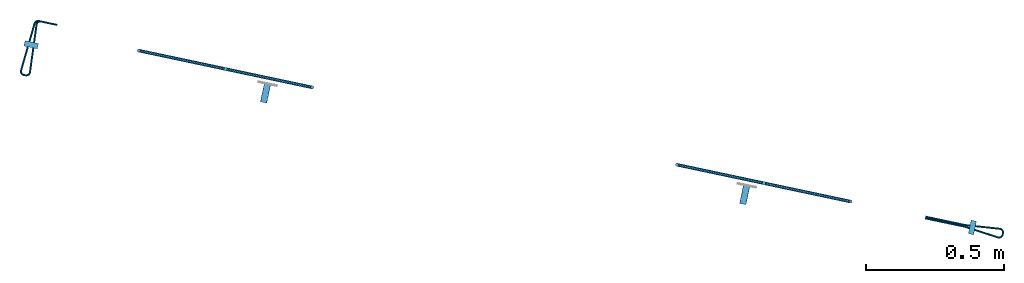
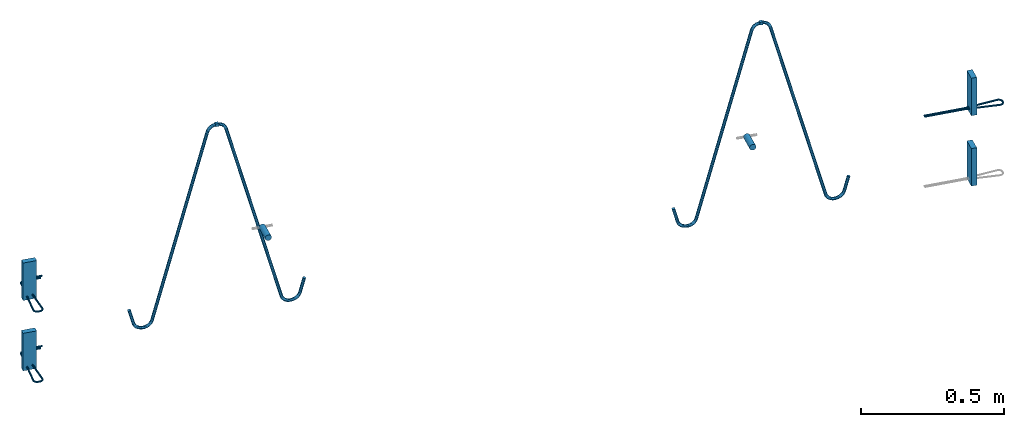
# One storey, part 1 of 2: 5 reinforcing bars, 4 beams, 4 plates, 8 elements without a shape of their own.
"""IFC2X3 building model written with IfcOpenShell, lengths in millimetres."""

from ifc_helpers import new_model, entity, si_unit, frame, origin_with_axes, origin_2d_with_axis, place, context, subcontext, project, spatial, polyline, rectangle, circle, outline, extrude, source, transform, mapped, material, type_object, element, aggregate, save


model = new_model("IFC2X3")

# Units and contexts
model_context = context("Model", 3, precision=1e-05, world=origin_with_axes())
body_context = subcontext(model_context, "Body", "Model", "MODEL_VIEW")
ifc_project = project(units=[si_unit("LENGTHUNIT", "METRE", prefix="MILLI"), si_unit("AREAUNIT", "SQUARE_METRE"), si_unit("VOLUMEUNIT", "CUBIC_METRE"), si_unit("MASSUNIT", "GRAM", prefix="KILO"), si_unit("TIMEUNIT", "SECOND"), si_unit("PLANEANGLEUNIT", "RADIAN"), si_unit("SOLIDANGLEUNIT", "STERADIAN"), si_unit("THERMODYNAMICTEMPERATUREUNIT", "DEGREE_CELSIUS"), si_unit("LUMINOUSINTENSITYUNIT", "LUMEN")], contexts=[model_context])

# Site, building, storey
site_placement = place(None, origin_with_axes())
site = spatial("IfcSite", under=ifc_project, at=site_placement, CompositionType="ELEMENT")
building_placement = place(site_placement, origin_with_axes())
building = spatial("IfcBuilding", under=site, at=building_placement, Name="Undefined", CompositionType="ELEMENT")
storey_placement = place(building_placement, origin_with_axes())
storey = spatial("IfcBuildingStorey", under=building, at=storey_placement, Name="Undefined", CompositionType="ELEMENT", Elevation=0.0)

# Assembly, beam
assembly_1_placement = place(storey_placement, origin_with_axes())
assembly_1 = element("IfcElementAssembly", 1, at=assembly_1_placement, inside=storey, Name="Steel Assembly", AssemblyPlace="NOTDEFINED", PredefinedType="RIGID_FRAME")
ifc_material_1 = material()
beam_type_1 = type_object("IfcBeamType", Name="D24", PredefinedType="NOTDEFINED")
beam_1_placement = place(assembly_1_placement, frame((1205.09818698197, 5717.25932723562, 670.000000007887), z_axis=(0.0, 0.0, 1.0), x_axis=(0.207475094085646, 0.978240300403818, 0.0)))
beam_1 = element("IfcBeam", 2, at=beam_1_placement, type_object=beam_type_1, material=ifc_material_1, ObjectType="D24", context=body_context, shape_type="SweptSolid", body=[
    extrude(circle(Radius=12.0, at=origin_2d_with_axis()), frame((70.0000000001488, 0.0, -1.13686837721616e-13), z_axis=(-1.0, 0.0, -6.18717668181185e-14), x_axis=(0.0, -1.0, 0.0)), (0.0, 0.0, 1.0), 70.0),
])
aggregate(assembly_1, [beam_1])

assembly_2_placement = place(storey_placement, origin_with_axes())
assembly_2 = element("IfcElementAssembly", 3, at=assembly_2_placement, inside=storey, Name="Steel Assembly", AssemblyPlace="NOTDEFINED", PredefinedType="RIGID_FRAME")
beam_2_placement = place(assembly_2_placement, frame((2946.52448996823, 5347.92002929886, 670.0), z_axis=(0.0, 0.0, 1.0), x_axis=(0.207475094085646, 0.978240300403818, 0.0)))
beam_2 = element("IfcBeam", 4, at=beam_2_placement, type_object=beam_type_1, material=ifc_material_1, ObjectType="D24", context=body_context, shape_type="SweptSolid", body=[
    extrude(circle(Radius=12.0, at=origin_2d_with_axis()), frame((70.0000000001488, 0.0, -1.13686837721616e-13), z_axis=(-1.0, 0.0, -6.18717668181185e-14), x_axis=(0.0, -1.0, 0.0)), (0.0, 0.0, 1.0), 70.0),
])
aggregate(assembly_2, [beam_2])

assembly_3_placement = place(storey_placement, origin_with_axes())
assembly_3 = element("IfcElementAssembly", 5, at=assembly_3_placement, inside=storey, Name="Steel Assembly", AssemblyPlace="NOTDEFINED", PredefinedType="RIGID_FRAME")
ifc_material_2 = material(Name="STEEL/S235JR")
beam_type_2 = type_object("IfcBeamType", Name="12X12", PredefinedType="NOTDEFINED")
beam_3_placement = place(assembly_3_placement, frame((3029.02681596481, 5422.63708332136, 1129.0), z_axis=(0.0, 0.0, 1.0), x_axis=(-0.978240300403818, 0.207475094085646, 0.0)))
beam_3 = element("IfcBeam", 6, at=beam_3_placement, type_object=beam_type_2, material=ifc_material_2, Name="SA_12", ObjectType="12X12", context=body_context, shape_type="SweptSolid", body=[
    extrude(rectangle(XDim=12.0, YDim=12.0, at=origin_2d_with_axis()), frame((11.9999999999924, 9.09494701772928e-13, 0.0), z_axis=(-1.0, 0.0, -6.18717668181185e-14), x_axis=(0.0, -1.0, 0.0)), (0.0, 0.0, 1.0), 12.0),
])

assembly_4_placement = place(storey_placement, origin_with_axes())
assembly_4 = element("IfcElementAssembly", 7, at=assembly_4_placement, inside=storey, Name="Steel Assembly", AssemblyPlace="NOTDEFINED", PredefinedType="RIGID_FRAME")
beam_4_placement = place(assembly_4_placement, frame((1060.80733155343, 5840.07697262104, 1129.0), z_axis=(0.0, 0.0, 1.0), x_axis=(0.978240300403819, -0.207475094085641, 0.0)))
beam_4 = element("IfcBeam", 8, at=beam_4_placement, type_object=beam_type_2, material=ifc_material_2, Name="SA_12", ObjectType="12X12", context=body_context, shape_type="SweptSolid", body=[
    extrude(rectangle(XDim=12.0, YDim=12.0, at=origin_2d_with_axis()), frame((11.9999999999924, 9.09494701772928e-13, 0.0), z_axis=(-1.0, 0.0, -6.18717668181185e-14), x_axis=(0.0, -1.0, 0.0)), (0.0, 0.0, 1.0), 12.0),
])

# Assembly, plate
assembly_5_placement = place(storey_placement, origin_with_axes())
assembly_5 = element("IfcElementAssembly", 9, at=assembly_5_placement, inside=storey, Name="Steel Assembly", AssemblyPlace="NOTDEFINED", PredefinedType="RIGID_FRAME")
ifc_material_3 = material(Name="STEEL/Steel_Undefined")
plate_type = type_object("IfcPlateType", Name="PL160X20", PredefinedType="NOTDEFINED")
plate_1_placement = place(assembly_5_placement, frame((3796.01503632393, 5285.3095123764, 662.5), z_axis=(0.0, 0.0, -1.0), x_axis=(-0.207475094085645, -0.978240300403818, 0.0)))
plate_1 = element("IfcPlate", 10, at=plate_1_placement, type_object=plate_type, material=ifc_material_3, Name="PVL100", ObjectType="PL160X20", context=body_context, shape_type="SweptSolid", body=[
    extrude(outline(polyline([(0.0, 0.0), (49.9999999999718, 1.81898940354586e-12), (49.9999999999718, 19.9999999999891), (-9.09494701772928e-13, 19.9999999999891), (0.0, 0.0)])), frame((9.09494701772928e-13, 0.0, -80.0), z_axis=(0.0, 0.0, 1.0), x_axis=(1.0, 0.0, 0.0)), (0.0, 0.0, 1.0), 160.0),
])

assembly_6_placement = place(storey_placement, origin_with_axes())
assembly_6 = element("IfcElementAssembly", 11, at=assembly_6_placement, inside=storey, Name="Steel Assembly", AssemblyPlace="NOTDEFINED", PredefinedType="RIGID_FRAME")
plate_2_placement = place(assembly_6_placement, frame((3796.01503632393, 5285.3095123764, 362.5), z_axis=(0.0, 0.0, -1.0), x_axis=(-0.207475094085645, -0.978240300403818, 0.0)))
plate_2 = element("IfcPlate", 12, at=plate_2_placement, type_object=plate_type, material=ifc_material_3, Name="PVL100", ObjectType="PL160X20", context=body_context, shape_type="SweptSolid", body=[
    extrude(outline(polyline([(0.0, 0.0), (49.9999999999718, 1.81898940354586e-12), (49.9999999999718, 19.9999999999891), (-9.09494701772928e-13, 19.9999999999891), (0.0, 0.0)])), frame((9.09494701772928e-13, 0.0, -80.0), z_axis=(0.0, 0.0, 1.0), x_axis=(1.0, 0.0, 0.0)), (0.0, 0.0, 1.0), 160.0),
])
aggregate(assembly_6, [plate_2])

assembly_7_placement = place(storey_placement, origin_with_axes())
assembly_7 = element("IfcElementAssembly", 13, at=assembly_7_placement, inside=storey, Name="Steel Assembly", AssemblyPlace="NOTDEFINED", PredefinedType="RIGID_FRAME")
plate_3_placement = place(assembly_7_placement, frame((382.791888165979, 5912.10723635699, 662.5), z_axis=(0.0, 0.0, -1.0), x_axis=(-0.978240300403818, 0.207475094085646, 0.0)))
plate_3 = element("IfcPlate", 14, at=plate_3_placement, type_object=plate_type, material=ifc_material_3, Name="PVL100", ObjectType="PL160X20", context=body_context, shape_type="SweptSolid", body=[
    extrude(outline(polyline([(0.0, 0.0), (49.9999999999718, 1.81898940354586e-12), (49.9999999999718, 19.9999999999891), (-9.09494701772928e-13, 19.9999999999891), (0.0, 0.0)])), frame((9.09494701772928e-13, 0.0, -80.0), z_axis=(0.0, 0.0, 1.0), x_axis=(1.0, 0.0, 0.0)), (0.0, 0.0, 1.0), 160.0),
])

assembly_8_placement = place(storey_placement, origin_with_axes())
assembly_8 = element("IfcElementAssembly", 15, at=assembly_8_placement, inside=storey, Name="Steel Assembly", AssemblyPlace="NOTDEFINED", PredefinedType="RIGID_FRAME")
plate_4_placement = place(assembly_8_placement, frame((382.791888165977, 5912.10723635699, 362.5), z_axis=(0.0, 0.0, -1.0), x_axis=(-0.978240300403818, 0.207475094085646, 0.0)))
plate_4 = element("IfcPlate", 16, at=plate_4_placement, type_object=plate_type, material=ifc_material_3, Name="PVL100", ObjectType="PL160X20", context=body_context, shape_type="SweptSolid", body=[
    extrude(outline(polyline([(0.0, 0.0), (49.9999999999718, 1.81898940354586e-12), (49.9999999999718, 19.9999999999891), (-9.09494701772928e-13, 19.9999999999891), (0.0, 0.0)])), frame((9.09494701772928e-13, 0.0, -80.0), z_axis=(0.0, 0.0, 1.0), x_axis=(1.0, 0.0, 0.0)), (0.0, 0.0, 1.0), 160.0),
])

# Reinforcing bar
ifc_material_4 = material(Name="Undefined")
ifc_direction_1 = entity("IfcDirection", [-1.0, 0.0, -6.18717668181185e-14])
ifc_direction_2 = entity("IfcDirection", [0.0, -1.0, 0.0])
ifc_direction_3 = entity("IfcDirection", [0.0, 0.0, 1.0])
ifc_direction_4 = entity("IfcDirection", [0.0, 1.0, 0.0])
shared_shape_1 = source(origin_with_axes(), body_context, "Body", "AdvancedSweptSolid", [
    entity("IfcSweptDiskSolid", entity("IfcCompositeCurve", [entity("IfcCompositeCurveSegment", "CONTINUOUS", True, entity("IfcTrimmedCurve", entity("IfcLine", entity("IfcCartesianPoint", [0.0, 0.0, 0.0]), entity("IfcVector", ifc_direction_1, 1.0)), [entity("IfcParameterValue", 0.0)], [entity("IfcParameterValue", 146.307676653139)], True, "PARAMETER")), entity("IfcCompositeCurveSegment", "CONTINUOUS", True, entity("IfcTrimmedCurve", entity("IfcCircle", entity("IfcAxis2Placement3D", entity("IfcCartesianPoint", [-146.307676653138, 0.0, -13.5000000000091]), ifc_direction_2, ifc_direction_3), 13.5), [entity("IfcParameterValue", 0.0)], [entity("IfcParameterValue", 0.102476647918938)], True, "PARAMETER")), entity("IfcCompositeCurveSegment", "CONTINUOUS", True, entity("IfcTrimmedCurve", entity("IfcLine", entity("IfcCartesianPoint", [-147.688691322892, 0.0, -0.0708228665461039]), entity("IfcVector", entity("IfcDirection", [-0.994753861737996, 0.0, -0.102297382944742]), 1.0)), [entity("IfcParameterValue", 0.0)], [entity("IfcParameterValue", 126.091788966003)], True, "PARAMETER")), entity("IfcCompositeCurveSegment", "CONTINUOUS", True, entity("IfcTrimmedCurve", entity("IfcCircle", entity("IfcAxis2Placement3D", entity("IfcCartesianPoint", [-274.500000000029, 0.0, 0.459494244874097]), ifc_direction_4, entity("IfcDirection", [0.102297382944742, 0.0, -0.994753861737996])), 13.5), [entity("IfcParameterValue", 0.0)], [entity("IfcParameterValue", 1.67327297471384)], True, "PARAMETER")), entity("IfcCompositeCurveSegment", "CONTINUOUS", True, entity("IfcTrimmedCurve", entity("IfcLine", entity("IfcCartesianPoint", [-288.000000000029, 0.0, 0.459494244873392]), entity("IfcVector", ifc_direction_3, 1.0)), [entity("IfcParameterValue", 0.0)], [entity("IfcParameterValue", 5.08101151022067)], True, "PARAMETER")), entity("IfcCompositeCurveSegment", "CONTINUOUS", True, entity("IfcTrimmedCurve", entity("IfcCircle", entity("IfcAxis2Placement3D", entity("IfcCartesianPoint", [-274.50000000003, 0.0, 5.54050575509475]), ifc_direction_4, ifc_direction_1), 13.5), [entity("IfcParameterValue", 0.0)], [entity("IfcParameterValue", 1.67327297471383)], True, "PARAMETER")), entity("IfcCompositeCurveSegment", "CONTINUOUS", True, entity("IfcTrimmedCurve", entity("IfcLine", entity("IfcCartesianPoint", [-273.118985330277, 0.0, 18.9696828885579]), entity("IfcVector", entity("IfcDirection", [0.994753861738008, 0.0, -0.102297382944626]), 1.0)), [entity("IfcParameterValue", 0.0)], [entity("IfcParameterValue", 126.091788966003)], True, "PARAMETER")), entity("IfcCompositeCurveSegment", "CONTINUOUS", True, entity("IfcTrimmedCurve", entity("IfcCircle", entity("IfcAxis2Placement3D", entity("IfcCartesianPoint", [-146.307676653139, 0.0, 19.4999999999928]), ifc_direction_2, entity("IfcDirection", [-0.102297382944626, 0.0, -0.994753861738008])), 13.5), [entity("IfcParameterValue", 0.0)], [entity("IfcParameterValue", 0.102476647918945)], True, "PARAMETER")), entity("IfcCompositeCurveSegment", "DISCONTINUOUS", True, entity("IfcTrimmedCurve", entity("IfcLine", entity("IfcCartesianPoint", [-146.307676653139, 0.0, 5.99999999999277]), entity("IfcVector", entity("IfcDirection", [1.0, 0.0, 0.0]), 1.0)), [entity("IfcParameterValue", 0.0)], [entity("IfcParameterValue", 146.307676653138)], True, "PARAMETER"))], False), 3.5, None, 0.0, 553.431441993769),
])
reinforcing_bar_1_placement = place(assembly_5_placement, frame((3753.03260227416, 5265.80283754038, 600.0), z_axis=(-0.207475094085645, -0.978240300403818, 0.0), x_axis=(-0.978240300403818, 0.207475094085646, 0.0)))
reinforcing_bar_1 = element("IfcReinforcingBar", 17, at=reinforcing_bar_1_placement, material=ifc_material_4, Name="PVL100", BarRole="NOTDEFINED", CrossSectionArea=0.0, NominalDiameter=7.0, context=body_context, shape_type="MappedRepresentation", body=[
    mapped(shared_shape_1, transform((147.000000000015, 0.0, -5.99999999999272))),
])

aggregate(assembly_5, [plate_1, reinforcing_bar_1])

ifc_direction_5 = entity("IfcDirection", [-0.0712470499880476, 0.0, -0.997458699830725])
ifc_direction_6 = entity("IfcDirection", [0.0392782283688239, 0.999224373928917, -0.00280558774063778])
shared_shape_2 = source(origin_with_axes(), body_context, "Body", "AdvancedSweptSolid", [
    entity("IfcSweptDiskSolid", entity("IfcCompositeCurve", [entity("IfcCompositeCurveSegment", "CONTINUOUS", True, entity("IfcTrimmedCurve", entity("IfcLine", entity("IfcCartesianPoint", [0.0, 0.0, 0.0]), entity("IfcVector", ifc_direction_5, 1.0)), [entity("IfcParameterValue", 0.0)], [entity("IfcParameterValue", 60.5013193255104)], True, "PARAMETER")), entity("IfcCompositeCurveSegment", "CONTINUOUS", True, entity("IfcTrimmedCurve", entity("IfcCircle", entity("IfcAxis2Placement3D", entity("IfcCartesianPoint", [9.15515192538732, 0.0, -61.3094024873058]), entity("IfcDirection", [0.0, -1.0, 0.0]), entity("IfcDirection", [-0.997458699830725, 0.0, 0.0712470499880475])), 13.5), [entity("IfcParameterValue", 0.0)], [entity("IfcParameterValue", 1.64210379158048)], True, "PARAMETER")), entity("IfcCompositeCurveSegment", "CONTINUOUS", True, entity("IfcTrimmedCurve", entity("IfcLine", entity("IfcCartesianPoint", [9.15515192538938, 0.0, -74.8094024873058]), entity("IfcVector", entity("IfcDirection", [1.0, 0.0, 0.0]), 1.0)), [entity("IfcParameterValue", 0.0)], [entity("IfcParameterValue", 174.519836941359)], True, "PARAMETER")), entity("IfcCompositeCurveSegment", "CONTINUOUS", True, entity("IfcTrimmedCurve", entity("IfcCircle", entity("IfcAxis2Placement3D", entity("IfcCartesianPoint", [183.674988866751, 0.0, -88.3094024872791]), entity("IfcDirection", [0.0, 1.0, 0.0]), entity("IfcDirection", [0.0, 0.0, 1.0])), 13.5), [entity("IfcParameterValue", 0.0)], [entity("IfcParameterValue", 1.64210379158053)], True, "PARAMETER")), entity("IfcCompositeCurveSegment", "CONTINUOUS", True, entity("IfcTrimmedCurve", entity("IfcLine", entity("IfcCartesianPoint", [197.140681314466, 0.0, -89.2712376621184]), entity("IfcVector", ifc_direction_5, 1.0)), [entity("IfcParameterValue", 0.0)], [entity("IfcParameterValue", 6.00343984306175)], True, "PARAMETER")), entity("IfcCompositeCurveSegment", "CONTINUOUS", True, entity("IfcTrimmedCurve", entity("IfcCircle", entity("IfcAxis2Placement3D", entity("IfcCartesianPoint", [183.257705830279, 0.531607056080731, -94.2983318120891]), ifc_direction_6, entity("IfcDirection", [0.996685044858304, -0.0393783004504245, -0.0711917889186412])), 13.5), [entity("IfcParameterValue", 0.0)], [entity("IfcParameterValue", 1.64204867072848)], True, "PARAMETER")), entity("IfcCompositeCurveSegment", "CONTINUOUS", True, entity("IfcTrimmedCurve", entity("IfcLine", entity("IfcCartesianPoint", [181.340404238493, 0.5694532623548, -107.661434830131]), entity("IfcVector", entity("IfcDirection", [-0.989083856748025, 0.0392783829555405, 0.142022297379144]), 1.0)), [entity("IfcParameterValue", 0.0)], [entity("IfcParameterValue", 176.605689080693)], True, "PARAMETER")), entity("IfcCompositeCurveSegment", "CONTINUOUS", True, entity("IfcTrimmedCurve", entity("IfcCircle", entity("IfcAxis2Placement3D", entity("IfcCartesianPoint", [8.57986975070497, 7.46839294391927, -69.2163861186222]), ifc_direction_6, entity("IfcDirection", [-0.142022340132314, 0.00280342268697104, -0.98985948281793])), 13.5), [entity("IfcParameterValue", 0.0)], [entity("IfcParameterValue", 1.49954398286124)], True, "PARAMETER")), entity("IfcCompositeCurveSegment", "DISCONTINUOUS", True, entity("IfcTrimmedCurve", entity("IfcLine", entity("IfcCartesianPoint", [-4.87537835488221, 8.0, -68.2552969682216]), entity("IfcVector", entity("IfcDirection", [0.0712470499880234, 0.0, 0.997458699830727]), 1.0)), [entity("IfcParameterValue", 0.0)], [entity("IfcParameterValue", 62.4291960958429)], True, "PARAMETER"))], False), 3.5, None, 0.0, 486.485281523218),
])
reinforcing_bar_2_placement = place(assembly_7_placement, frame((382.018110965612, 6014.49571846721, 600.0), z_axis=(0.990536286572108, -0.13725110194071, 0.0), x_axis=(-0.13725110194071, -0.990536286572108, 0.0)))
reinforcing_bar_2 = element("IfcReinforcingBar", 18, at=reinforcing_bar_2_placement, material=ifc_material_4, Name="PVL100", BarRole="NOTDEFINED", CrossSectionArea=0.0, NominalDiameter=7.0, context=body_context, shape_type="MappedRepresentation", body=[
    mapped(shared_shape_2, transform((5.34352874910383, 1.13686837721616e-13, 74.809402487308))),
])

aggregate(assembly_7, [plate_3, reinforcing_bar_2])

ifc_direction_7 = entity("IfcDirection", [-0.0712470499880476, 0.0, -0.997458699830725])
ifc_direction_8 = entity("IfcDirection", [0.0392782283688239, 0.999224373928917, -0.00280558774063778])
shared_shape_3 = source(origin_with_axes(), body_context, "Body", "AdvancedSweptSolid", [
    entity("IfcSweptDiskSolid", entity("IfcCompositeCurve", [entity("IfcCompositeCurveSegment", "CONTINUOUS", True, entity("IfcTrimmedCurve", entity("IfcLine", entity("IfcCartesianPoint", [0.0, 0.0, 0.0]), entity("IfcVector", ifc_direction_7, 1.0)), [entity("IfcParameterValue", 0.0)], [entity("IfcParameterValue", 60.5013193255105)], True, "PARAMETER")), entity("IfcCompositeCurveSegment", "CONTINUOUS", True, entity("IfcTrimmedCurve", entity("IfcCircle", entity("IfcAxis2Placement3D", entity("IfcCartesianPoint", [9.15515192538732, 0.0, -61.3094024873058]), entity("IfcDirection", [0.0, -1.0, 0.0]), entity("IfcDirection", [-0.997458699830725, 0.0, 0.0712470499880475])), 13.5), [entity("IfcParameterValue", 0.0)], [entity("IfcParameterValue", 1.64210379158046)], True, "PARAMETER")), entity("IfcCompositeCurveSegment", "CONTINUOUS", True, entity("IfcTrimmedCurve", entity("IfcLine", entity("IfcCartesianPoint", [9.15515192538938, 0.0, -74.8094024873058]), entity("IfcVector", entity("IfcDirection", [1.0, 0.0, 0.0]), 1.0)), [entity("IfcParameterValue", 0.0)], [entity("IfcParameterValue", 174.519836941359)], True, "PARAMETER")), entity("IfcCompositeCurveSegment", "CONTINUOUS", True, entity("IfcTrimmedCurve", entity("IfcCircle", entity("IfcAxis2Placement3D", entity("IfcCartesianPoint", [183.674988866751, 0.0, -88.3094024872791]), entity("IfcDirection", [0.0, 1.0, 0.0]), entity("IfcDirection", [0.0, 0.0, 1.0])), 13.5), [entity("IfcParameterValue", 0.0)], [entity("IfcParameterValue", 1.64210379158045)], True, "PARAMETER")), entity("IfcCompositeCurveSegment", "CONTINUOUS", True, entity("IfcTrimmedCurve", entity("IfcLine", entity("IfcCartesianPoint", [197.140681314466, 0.0, -89.2712376621184]), entity("IfcVector", ifc_direction_7, 1.0)), [entity("IfcParameterValue", 0.0)], [entity("IfcParameterValue", 6.00343984306127)], True, "PARAMETER")), entity("IfcCompositeCurveSegment", "CONTINUOUS", True, entity("IfcTrimmedCurve", entity("IfcCircle", entity("IfcAxis2Placement3D", entity("IfcCartesianPoint", [183.257705830279, 0.531607056080731, -94.2983318120891]), ifc_direction_8, entity("IfcDirection", [0.996685044858304, -0.0393783004504245, -0.0711917889186412])), 13.5), [entity("IfcParameterValue", 0.0)], [entity("IfcParameterValue", 1.64204867072856)], True, "PARAMETER")), entity("IfcCompositeCurveSegment", "CONTINUOUS", True, entity("IfcTrimmedCurve", entity("IfcLine", entity("IfcCartesianPoint", [181.340404238493, 0.5694532623548, -107.661434830131]), entity("IfcVector", entity("IfcDirection", [-0.989083856748025, 0.0392783829555405, 0.142022297379144]), 1.0)), [entity("IfcParameterValue", 0.0)], [entity("IfcParameterValue", 176.605689080693)], True, "PARAMETER")), entity("IfcCompositeCurveSegment", "CONTINUOUS", True, entity("IfcTrimmedCurve", entity("IfcCircle", entity("IfcAxis2Placement3D", entity("IfcCartesianPoint", [8.57986975070497, 7.46839294391927, -69.2163861186222]), ifc_direction_8, entity("IfcDirection", [-0.142022340132314, 0.00280342268697104, -0.98985948281793])), 13.5), [entity("IfcParameterValue", 0.0)], [entity("IfcParameterValue", 1.49954398286124)], True, "PARAMETER")), entity("IfcCompositeCurveSegment", "DISCONTINUOUS", True, entity("IfcTrimmedCurve", entity("IfcLine", entity("IfcCartesianPoint", [-4.87537835488221, 8.0, -68.2552969682216]), entity("IfcVector", entity("IfcDirection", [0.0712470499880234, 0.0, 0.997458699830727]), 1.0)), [entity("IfcParameterValue", 0.0)], [entity("IfcParameterValue", 62.429196095843)], True, "PARAMETER"))], False), 3.5, None, 0.0, 486.485281523217),
])
reinforcing_bar_3_placement = place(assembly_8_placement, frame((382.01811096561, 6014.49571846721, 300.0), z_axis=(0.990536286572108, -0.13725110194071, 0.0), x_axis=(-0.13725110194071, -0.990536286572108, 0.0)))
reinforcing_bar_3 = element("IfcReinforcingBar", 19, at=reinforcing_bar_3_placement, material=ifc_material_4, Name="PVL100", BarRole="NOTDEFINED", CrossSectionArea=0.0, NominalDiameter=7.0, context=body_context, shape_type="MappedRepresentation", body=[
    mapped(shared_shape_3, transform((5.34352874910383, 1.13686837721616e-13, 74.809402487308))),
])

aggregate(assembly_8, [plate_4, reinforcing_bar_3])

ifc_material_5 = material(Name="S235JR")
ifc_direction_9 = entity("IfcDirection", [-0.866025403784517, -2.13907072149269e-13, -0.499999999999865])
ifc_direction_10 = entity("IfcDirection", [0.0, -1.0, 0.0])
ifc_direction_11 = entity("IfcDirection", [-0.499999999999865, -1.60487990737634e-13, 0.866025403784517])
vector_1 = entity("IfcVector", entity("IfcDirection", [1.0, 0.0, 0.0]), 1.0)
ifc_direction_12 = entity("IfcDirection", [0.0, 1.0, 0.0])
shared_shape_4 = source(origin_with_axes(), body_context, "Body", "AdvancedSweptSolid", [
    entity("IfcSweptDiskSolid", entity("IfcCompositeCurve", [entity("IfcCompositeCurveSegment", "CONTINUOUS", True, entity("IfcTrimmedCurve", entity("IfcLine", entity("IfcCartesianPoint", [0.0, 0.0, 0.0]), entity("IfcVector", ifc_direction_9, 1.0)), [entity("IfcParameterValue", 0.0)], [entity("IfcParameterValue", 61.1547005383758)], True, "PARAMETER")), entity("IfcCompositeCurveSegment", "CONTINUOUS", True, entity("IfcTrimmedCurve", entity("IfcCircle", entity("IfcAxis2Placement3D", entity("IfcCartesianPoint", [-35.9615242270727, -7.6248312552497e-12, -60.0222139978532]), ifc_direction_10, ifc_direction_11), 34.0), [entity("IfcParameterValue", 0.0)], [entity("IfcParameterValue", 1.04719755119665)], True, "PARAMETER")), entity("IfcCompositeCurveSegment", "CONTINUOUS", True, entity("IfcTrimmedCurve", entity("IfcLine", entity("IfcCartesianPoint", [-69.9615242270727, -1.66515916878236e-11, -60.0222139978497]), entity("IfcVector", entity("IfcDirection", [0.0, 0.0, -1.0]), 1.0)), [entity("IfcParameterValue", 0.0)], [entity("IfcParameterValue", 3.15470053835764)], True, "PARAMETER")), entity("IfcCompositeCurveSegment", "CONTINUOUS", True, entity("IfcTrimmedCurve", entity("IfcCircle", entity("IfcAxis2Placement3D", entity("IfcCartesianPoint", [-35.961524227073, -7.36248289413522e-12, -63.1769145362108]), ifc_direction_10, entity("IfcDirection", [-1.0, 0.0, -6.18717668181185e-14])), 34.0), [entity("IfcParameterValue", 0.0)], [entity("IfcParameterValue", 1.57079632679499)], True, "PARAMETER")), entity("IfcCompositeCurveSegment", "CONTINUOUS", True, entity("IfcTrimmedCurve", entity("IfcLine", entity("IfcCartesianPoint", [-35.9615242270734, -6.27335610331363e-12, -97.1769145362108]), vector_1), [entity("IfcParameterValue", 0.0)], [entity("IfcParameterValue", 784.662984564384)], True, "PARAMETER")), entity("IfcCompositeCurveSegment", "CONTINUOUS", True, entity("IfcTrimmedCurve", entity("IfcCircle", entity("IfcAxis2Placement3D", entity("IfcCartesianPoint", [748.70146033731, 2.06206879476125e-10, -131.176914536219]), ifc_direction_12, entity("IfcDirection", [0.0, 0.0, 1.0])), 34.0), [entity("IfcParameterValue", 0.0)], [entity("IfcParameterValue", 1.30899693899588)], True, "PARAMETER")), entity("IfcCompositeCurveSegment", "CONTINUOUS", True, entity("IfcTrimmedCurve", entity("IfcLine", entity("IfcCartesianPoint", [781.54293843114, 2.14969178260719e-10, -122.377067002739]), entity("IfcVector", entity("IfcDirection", [0.258819045102363, 8.23108730427407e-14, -0.965925826289111]), 1.0)), [entity("IfcParameterValue", 0.0)], [entity("IfcParameterValue", 3.06930795188757)], True, "PARAMETER")), entity("IfcCompositeCurveSegment", "CONTINUOUS", True, entity("IfcTrimmedCurve", entity("IfcCircle", entity("IfcAxis2Placement3D", entity("IfcCartesianPoint", [749.495855690543, 2.06551446315979e-10, -134.141638355782]), ifc_direction_12, entity("IfcDirection", [0.965925826289105, 2.55010863585189e-13, 0.258819045102384])), 34.0), [entity("IfcParameterValue", 0.0)], [entity("IfcParameterValue", 1.30899693899598)], True, "PARAMETER")), entity("IfcCompositeCurveSegment", "CONTINUOUS", True, entity("IfcTrimmedCurve", entity("IfcLine", entity("IfcCartesianPoint", [766.495855690532, 2.11498713768827e-10, -163.58650208446]), entity("IfcVector", ifc_direction_9, 1.0)), [entity("IfcParameterValue", 0.0)], [entity("IfcParameterValue", 784.662984564355)], True, "PARAMETER")), entity("IfcCompositeCurveSegment", "CONTINUOUS", True, entity("IfcTrimmedCurve", entity("IfcCircle", entity("IfcAxis2Placement3D", entity("IfcCartesianPoint", [103.957777648324, 3.87473953780585e-11, -585.362858095057]), ifc_direction_10, ifc_direction_11), 34.0), [entity("IfcParameterValue", 0.0)], [entity("IfcParameterValue", 1.57079632679509)], True, "PARAMETER")), entity("IfcCompositeCurveSegment", "CONTINUOUS", True, entity("IfcTrimmedCurve", entity("IfcLine", entity("IfcCartesianPoint", [74.5129139196498, 3.10967848210611e-11, -602.362858095051]), entity("IfcVector", entity("IfcDirection", [0.499999999999841, 1.12115993172722e-13, -0.86602540378453]), 1.0)), [entity("IfcParameterValue", 0.0)], [entity("IfcParameterValue", 3.15470053835708)], True, "PARAMETER")), entity("IfcCompositeCurveSegment", "CONTINUOUS", True, entity("IfcTrimmedCurve", entity("IfcCircle", entity("IfcAxis2Placement3D", entity("IfcCartesianPoint", [105.535127917502, 3.98575908067272e-11, -588.094908902607]), ifc_direction_10, ifc_direction_9), 34.0), [entity("IfcParameterValue", 0.0)], [entity("IfcParameterValue", 1.04719755119656)], True, "PARAMETER")), entity("IfcCompositeCurveSegment", "DISCONTINUOUS", True, entity("IfcTrimmedCurve", entity("IfcLine", entity("IfcCartesianPoint", [105.535127917494, 3.89552741466794e-11, -622.094908902607]), vector_1), [entity("IfcParameterValue", 0.0)], [entity("IfcParameterValue", 61.1547005383798)], True, "PARAMETER"))], False), 6.0, None, 0.0, 1708.86806086807),
])
reinforcing_bar_4_placement = place(assembly_3_placement, frame((2782.25425086809, 5474.97510409197, 313.032127715824), z_axis=(-0.944907570463933, 0.200405552098396, 0.258819044832648), x_axis=(0.253187220094725, -0.0536985060200903, 0.96592582636138)))
reinforcing_bar_4 = element("IfcReinforcingBar", 20, at=reinforcing_bar_4_placement, material=ifc_material_5, Name="SA_12", BarRole="NOTDEFINED", CrossSectionArea=0.0, NominalDiameter=12.0, context=body_context, shape_type="MappedRepresentation", body=[
    mapped(shared_shape_4, transform((69.9615242270766, 1.63709046319127e-11, 97.1769145362107))),
])

aggregate(assembly_3, [beam_3, reinforcing_bar_4])

ifc_direction_13 = entity("IfcDirection", [-0.866025403784517, -2.13907072149269e-13, -0.499999999999865])
ifc_direction_14 = entity("IfcDirection", [0.0, -1.0, 0.0])
ifc_direction_15 = entity("IfcDirection", [-0.499999999999865, -1.60487990737634e-13, 0.866025403784517])
vector_2 = entity("IfcVector", entity("IfcDirection", [1.0, 0.0, 0.0]), 1.0)
ifc_direction_16 = entity("IfcDirection", [0.0, 1.0, 0.0])
shared_shape_5 = source(origin_with_axes(), body_context, "Body", "AdvancedSweptSolid", [
    entity("IfcSweptDiskSolid", entity("IfcCompositeCurve", [entity("IfcCompositeCurveSegment", "CONTINUOUS", True, entity("IfcTrimmedCurve", entity("IfcLine", entity("IfcCartesianPoint", [0.0, 0.0, 0.0]), entity("IfcVector", ifc_direction_13, 1.0)), [entity("IfcParameterValue", 0.0)], [entity("IfcParameterValue", 61.1547005383778)], True, "PARAMETER")), entity("IfcCompositeCurveSegment", "CONTINUOUS", True, entity("IfcTrimmedCurve", entity("IfcCircle", entity("IfcAxis2Placement3D", entity("IfcCartesianPoint", [-35.9615242270727, -7.6248312552497e-12, -60.0222139978532]), ifc_direction_14, ifc_direction_15), 34.0), [entity("IfcParameterValue", 0.0)], [entity("IfcParameterValue", 1.04719755119671)], True, "PARAMETER")), entity("IfcCompositeCurveSegment", "CONTINUOUS", True, entity("IfcTrimmedCurve", entity("IfcLine", entity("IfcCartesianPoint", [-69.9615242270727, -1.66515916878236e-11, -60.0222139978497]), entity("IfcVector", entity("IfcDirection", [0.0, 0.0, -1.0]), 1.0)), [entity("IfcParameterValue", 0.0)], [entity("IfcParameterValue", 3.15470053839107)], True, "PARAMETER")), entity("IfcCompositeCurveSegment", "CONTINUOUS", True, entity("IfcTrimmedCurve", entity("IfcCircle", entity("IfcAxis2Placement3D", entity("IfcCartesianPoint", [-35.961524227073, -7.36248289413522e-12, -63.1769145362108]), ifc_direction_14, entity("IfcDirection", [-1.0, 0.0, -6.18717668181185e-14])), 34.0), [entity("IfcParameterValue", 0.0)], [entity("IfcParameterValue", 1.5707963267947)], True, "PARAMETER")), entity("IfcCompositeCurveSegment", "CONTINUOUS", True, entity("IfcTrimmedCurve", entity("IfcLine", entity("IfcCartesianPoint", [-35.9615242270734, -6.27335610331363e-12, -97.1769145362108]), vector_2), [entity("IfcParameterValue", 0.0)], [entity("IfcParameterValue", 784.662984564465)], True, "PARAMETER")), entity("IfcCompositeCurveSegment", "CONTINUOUS", True, entity("IfcTrimmedCurve", entity("IfcCircle", entity("IfcAxis2Placement3D", entity("IfcCartesianPoint", [748.70146033731, 2.06206879476125e-10, -131.176914536219]), ifc_direction_16, entity("IfcDirection", [0.0, 0.0, 1.0])), 34.0), [entity("IfcParameterValue", 0.0)], [entity("IfcParameterValue", 1.3089969389957)], True, "PARAMETER")), entity("IfcCompositeCurveSegment", "CONTINUOUS", True, entity("IfcTrimmedCurve", entity("IfcLine", entity("IfcCartesianPoint", [781.54293843114, 2.14969178260719e-10, -122.377067002739]), entity("IfcVector", entity("IfcDirection", [0.258819045102363, 8.23108730427407e-14, -0.965925826289111]), 1.0)), [entity("IfcParameterValue", 0.0)], [entity("IfcParameterValue", 3.06930795192174)], True, "PARAMETER")), entity("IfcCompositeCurveSegment", "CONTINUOUS", True, entity("IfcTrimmedCurve", entity("IfcCircle", entity("IfcAxis2Placement3D", entity("IfcCartesianPoint", [749.495855690543, 2.06551446315979e-10, -134.141638355782]), ifc_direction_16, entity("IfcDirection", [0.965925826289105, 2.55010863585189e-13, 0.258819045102384])), 34.0), [entity("IfcParameterValue", 0.0)], [entity("IfcParameterValue", 1.30899693899593)], True, "PARAMETER")), entity("IfcCompositeCurveSegment", "CONTINUOUS", True, entity("IfcTrimmedCurve", entity("IfcLine", entity("IfcCartesianPoint", [766.495855690532, 2.11498713768827e-10, -163.58650208446]), entity("IfcVector", ifc_direction_13, 1.0)), [entity("IfcParameterValue", 0.0)], [entity("IfcParameterValue", 784.662984564398)], True, "PARAMETER")), entity("IfcCompositeCurveSegment", "CONTINUOUS", True, entity("IfcTrimmedCurve", entity("IfcCircle", entity("IfcAxis2Placement3D", entity("IfcCartesianPoint", [103.957777648324, 3.87473953780585e-11, -585.362858095057]), ifc_direction_14, ifc_direction_15), 34.0), [entity("IfcParameterValue", 0.0)], [entity("IfcParameterValue", 1.57079632679492)], True, "PARAMETER")), entity("IfcCompositeCurveSegment", "CONTINUOUS", True, entity("IfcTrimmedCurve", entity("IfcLine", entity("IfcCartesianPoint", [74.5129139196498, 3.10967848210611e-11, -602.362858095051]), entity("IfcVector", entity("IfcDirection", [0.499999999999841, 1.12115993172722e-13, -0.86602540378453]), 1.0)), [entity("IfcParameterValue", 0.0)], [entity("IfcParameterValue", 3.15470053839221)], True, "PARAMETER")), entity("IfcCompositeCurveSegment", "CONTINUOUS", True, entity("IfcTrimmedCurve", entity("IfcCircle", entity("IfcAxis2Placement3D", entity("IfcCartesianPoint", [105.535127917502, 3.98575908067272e-11, -588.094908902607]), ifc_direction_14, ifc_direction_13), 34.0), [entity("IfcParameterValue", 0.0)], [entity("IfcParameterValue", 1.04719755119649)], True, "PARAMETER")), entity("IfcCompositeCurveSegment", "DISCONTINUOUS", True, entity("IfcTrimmedCurve", entity("IfcLine", entity("IfcCartesianPoint", [105.535127917494, 3.89552741466794e-11, -622.094908902607]), vector_2), [entity("IfcParameterValue", 0.0)], [entity("IfcParameterValue", 61.1547005383878)], True, "PARAMETER"))], False), 6.0, None, 0.0, 1708.86806086831),
])
reinforcing_bar_5_placement = place(assembly_4_placement, frame((1307.57989665045, 5787.73895185023, 313.032127715824), z_axis=(0.944907570463933, -0.200405552098396, 0.258819044832648), x_axis=(-0.253187220094725, 0.0536985060200899, 0.96592582636138)))
reinforcing_bar_5 = element("IfcReinforcingBar", 21, at=reinforcing_bar_5_placement, material=ifc_material_5, Name="SA_12", BarRole="NOTDEFINED", CrossSectionArea=0.0, NominalDiameter=12.0, context=body_context, shape_type="MappedRepresentation", body=[
    mapped(shared_shape_5, transform((69.9615242270766, 1.63709046319127e-11, 97.1769145362107))),
])

aggregate(assembly_4, [beam_4, reinforcing_bar_5])

save(model, "model.ifc")
